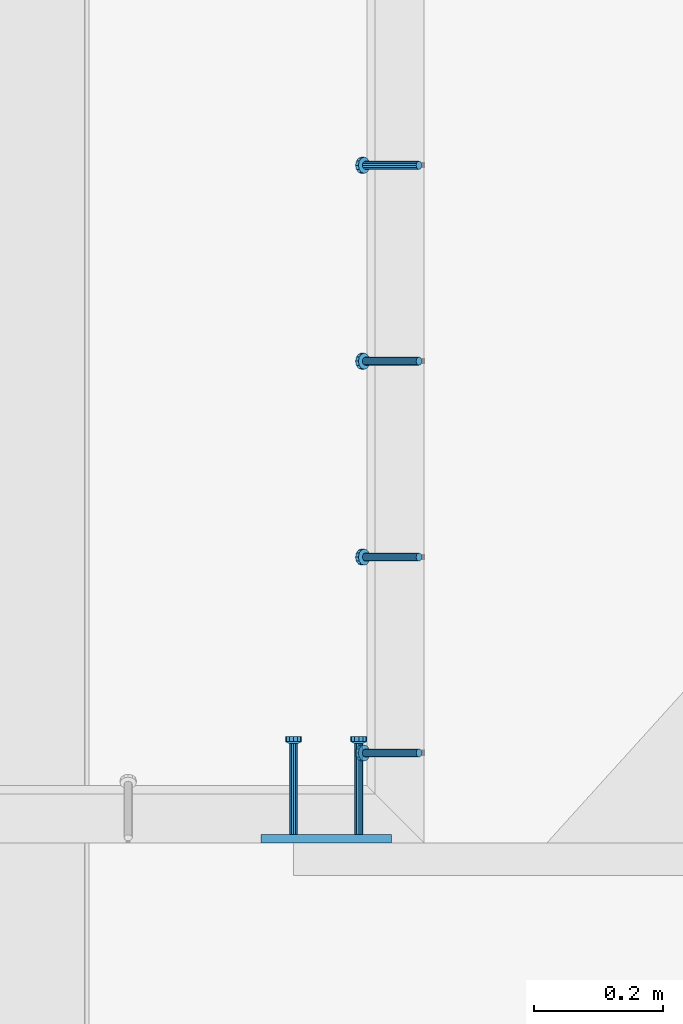
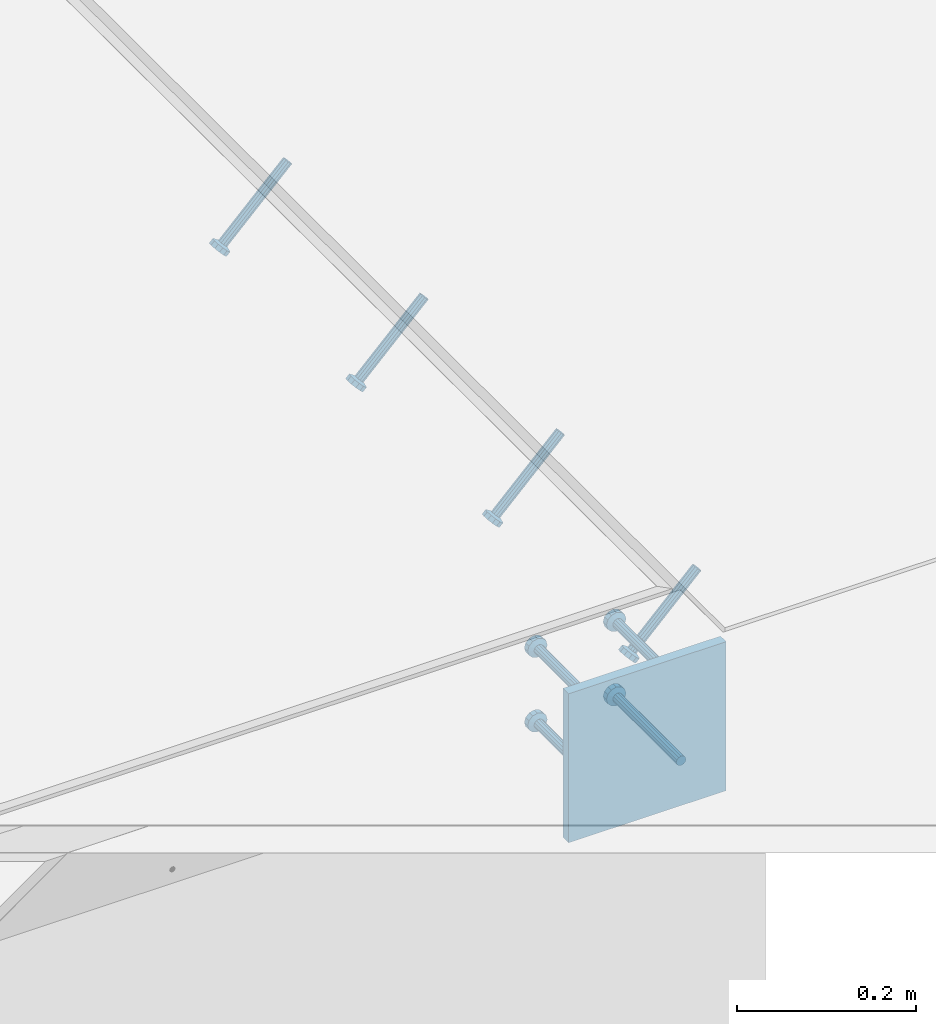
# One storey, part 2160 of 3843: 5 beams, 4 members, 2 elements without a shape of their own.
"""IFC2X3 building model written with IfcOpenShell, lengths in millimetres."""

from ifc_helpers import new_model, si_unit, frame, origin_with_axes, place, context, subcontext, project, spatial, faceted_brep, material, type_object, element, aggregate, save


model = new_model("IFC2X3")

# Units and contexts
model_context = context("Model", 3, precision=1e-05, world=origin_with_axes())
body_context = subcontext(model_context, "Body", "Model", "MODEL_VIEW")
ifc_project = project(units=[si_unit("LENGTHUNIT", "METRE", prefix="MILLI"), si_unit("AREAUNIT", "SQUARE_METRE"), si_unit("VOLUMEUNIT", "CUBIC_METRE"), si_unit("MASSUNIT", "GRAM", prefix="KILO"), si_unit("TIMEUNIT", "SECOND"), si_unit("PLANEANGLEUNIT", "RADIAN"), si_unit("SOLIDANGLEUNIT", "STERADIAN"), si_unit("THERMODYNAMICTEMPERATUREUNIT", "DEGREE_CELSIUS"), si_unit("LUMINOUSINTENSITYUNIT", "LUMEN")], contexts=[model_context])

# Site, building, storey
site_placement = place(None, origin_with_axes())
site = spatial("IfcSite", under=ifc_project, at=site_placement, CompositionType="ELEMENT")
building_placement = place(site_placement, origin_with_axes())
building = spatial("IfcBuilding", under=site, at=building_placement, Name="Undefined", CompositionType="ELEMENT")
storey_placement = place(building_placement, origin_with_axes())
storey = spatial("IfcBuildingStorey", under=building, at=storey_placement, Name="Undefined", CompositionType="ELEMENT", Elevation=0.0)

# Assembly, members
assembly_1_placement = place(storey_placement, origin_with_axes())
assembly_1 = element("IfcElementAssembly", 1, at=assembly_1_placement, inside=storey, Name="EMBED_ANGLE", AssemblyPlace="NOTDEFINED", PredefinedType="RIGID_FRAME")
ifc_material_1 = material(Name="STEEL/A108")
member_type = type_object("IfcMemberType", PredefinedType="NOTDEFINED")
member_1_placement = place(assembly_1_placement, frame((65137.5380556641, 28968.8271953125, 30446.6625), z_axis=(0.0, 1.0, 0.0), x_axis=(-0.707106781186548, 0.0, -0.707106781186548)))
member_1 = element("IfcMember", 2, at=member_1_placement, type_object=member_type, material=ifc_material_1, Name="HEADED STUD ANCHOR", context=body_context, shape_type="Brep", body=[
    faceted_brep([(7.27595761418343e-12, -3.18000006675175, 5.5), (0.0, -5.49999999998363, 3.1800000667572), (118.110000000976, -5.49999999999091, 3.1800000667572), (118.110000000983, -3.18000006675175, 5.5), (0.0, -6.3499999046162, 0.0), (118.110000000968, -6.34999990461256, 0.0), (0.0, -5.49999999998363, -3.1800000667572), (118.110000000976, -5.49999999999091, -3.1800000667572), (7.27595761418343e-12, -3.18000006675175, -5.5), (118.110000000983, -3.18000006675175, -5.5), (7.27595761418343e-12, -1.81898940354586e-12, -6.34999990463257), (118.110000000968, -1.81898940354586e-12, -6.34999990463257), (0.0, 3.18000006675175, -5.5), (118.110000000968, 3.18000006674811, -5.5), (7.27595761418343e-12, 5.49999999998363, -3.1800000667572), (118.110000000983, 5.49999999998363, -3.1800000667572), (7.27595761418343e-12, 6.3499999046162, 0.0), (118.110000000976, 6.34999990461256, 0.0), (7.27595761418343e-12, 5.49999999998363, 3.1800000667572), (118.110000000983, 5.49999999998363, 3.1800000667572), (0.0, 3.18000006675175, 5.5), (118.110000000968, 3.18000006674811, 5.5), (7.27595761418343e-12, -1.81898940354586e-12, 6.34999990463257), (118.110000000968, -1.81898940354586e-12, 6.34999990463257), (120.650000000991, -10.9899997710909, 6.34999990463257), (120.650000000998, -6.34000015257152, 10.9899997711182), (120.650000000991, -12.6999998092379, 0.0), (120.650000000991, -10.9899997710909, -6.34999990463257), (120.650000000998, -6.34000015257152, -10.9899997711182), (120.650000000991, -1.81898940354586e-12, -12.6899995803833), (120.650000000991, 6.34000015257152, -10.9899997711182), (120.650000000998, 10.9899997710909, -6.34999990463257), (120.650000000991, 12.6999998092342, 0.0), (120.650000000998, 10.9899997710909, 6.34999990463257), (120.650000000991, 6.34000015257152, 10.9899997711182), (120.650000000991, -1.81898940354586e-12, 12.6899995803833), (127.000000001048, -10.9899997710945, 6.34999990463257), (127.000000001048, -6.34000015257152, 10.9899997711182), (127.000000001048, -12.6999998092342, 0.0), (127.000000001048, -10.9899997710945, -6.34999990463257), (127.000000001048, -6.34000015257152, -10.9899997711182), (127.000000001048, 1.81898940354586e-12, -12.6899995803833), (127.000000001048, 6.34000015256788, -10.9899997711182), (127.000000001048, 10.9899997710909, -6.34999990463257), (127.000000001048, 12.6999998092379, 0.0), (127.000000001048, 10.9899997710909, 6.34999990463257), (127.000000001048, 6.34000015256788, 10.9899997711182), (127.000000001048, 1.81898940354586e-12, 12.6899995803833)], [[[0, 1, 2, 3]], [[1, 4, 5, 2]], [[4, 6, 7, 5]], [[6, 8, 9, 7]], [[8, 10, 11, 9]], [[10, 12, 13, 11]], [[12, 14, 15, 13]], [[14, 16, 17, 15]], [[16, 18, 19, 17]], [[18, 20, 21, 19]], [[20, 22, 23, 21]], [[22, 0, 3, 23]], [[22, 20, 18, 16, 14, 12, 10, 8, 6, 4, 1, 0]], [[3, 2, 24, 25]], [[2, 5, 26, 24]], [[5, 7, 27, 26]], [[7, 9, 28, 27]], [[9, 11, 29, 28]], [[11, 13, 30, 29]], [[13, 15, 31, 30]], [[15, 17, 32, 31]], [[17, 19, 33, 32]], [[19, 21, 34, 33]], [[21, 23, 35, 34]], [[23, 3, 25, 35]], [[25, 24, 36, 37]], [[24, 26, 38, 36]], [[26, 27, 39, 38]], [[27, 28, 40, 39]], [[28, 29, 41, 40]], [[29, 30, 42, 41]], [[30, 31, 43, 42]], [[31, 32, 44, 43]], [[32, 33, 45, 44]], [[33, 34, 46, 45]], [[34, 35, 47, 46]], [[35, 25, 37, 47]], [[38, 39, 40, 41, 42, 43, 44, 45, 46, 47, 37, 36]]]),
])
member_2_placement = place(assembly_1_placement, frame((65137.5380556641, 29273.6271953125, 30446.6625), z_axis=(0.0, 1.0, 0.0), x_axis=(-0.707106781186548, 0.0, -0.707106781186548)))
member_2 = element("IfcMember", 3, at=member_2_placement, type_object=member_type, material=ifc_material_1, Name="HEADED STUD ANCHOR", context=body_context, shape_type="Brep", body=[
    faceted_brep([(7.27595761418343e-12, -3.18000006675175, 5.5), (0.0, -5.49999999998363, 3.1800000667572), (118.110000000976, -5.49999999999091, 3.1800000667572), (118.110000000983, -3.18000006675175, 5.5), (0.0, -6.3499999046162, 0.0), (118.110000000968, -6.34999990461256, 0.0), (0.0, -5.49999999998363, -3.1800000667572), (118.110000000976, -5.49999999999091, -3.1800000667572), (7.27595761418343e-12, -3.18000006675175, -5.5), (118.110000000983, -3.18000006675175, -5.5), (7.27595761418343e-12, -1.81898940354586e-12, -6.34999990463257), (118.110000000968, -1.81898940354586e-12, -6.34999990463257), (0.0, 3.18000006675175, -5.5), (118.110000000968, 3.18000006674811, -5.5), (7.27595761418343e-12, 5.49999999998363, -3.1800000667572), (118.110000000983, 5.49999999998363, -3.1800000667572), (7.27595761418343e-12, 6.3499999046162, 0.0), (118.110000000976, 6.34999990461256, 0.0), (7.27595761418343e-12, 5.49999999998363, 3.1800000667572), (118.110000000983, 5.49999999998363, 3.1800000667572), (0.0, 3.18000006675175, 5.5), (118.110000000968, 3.18000006674811, 5.5), (7.27595761418343e-12, -1.81898940354586e-12, 6.34999990463257), (118.110000000968, -1.81898940354586e-12, 6.34999990463257), (120.650000000991, -10.9899997710909, 6.34999990463257), (120.650000000998, -6.34000015257152, 10.9899997711182), (120.650000000991, -12.6999998092379, 0.0), (120.650000000991, -10.9899997710909, -6.34999990463257), (120.650000000998, -6.34000015257152, -10.9899997711182), (120.650000000991, -1.81898940354586e-12, -12.6899995803833), (120.650000000991, 6.34000015257152, -10.9899997711182), (120.650000000998, 10.9899997710909, -6.34999990463257), (120.650000000991, 12.6999998092342, 0.0), (120.650000000998, 10.9899997710909, 6.34999990463257), (120.650000000991, 6.34000015257152, 10.9899997711182), (120.650000000991, -1.81898940354586e-12, 12.6899995803833), (127.000000001048, -10.9899997710945, 6.34999990463257), (127.000000001048, -6.34000015257152, 10.9899997711182), (127.000000001048, -12.6999998092342, 0.0), (127.000000001048, -10.9899997710945, -6.34999990463257), (127.000000001048, -6.34000015257152, -10.9899997711182), (127.000000001048, 1.81898940354586e-12, -12.6899995803833), (127.000000001048, 6.34000015256788, -10.9899997711182), (127.000000001048, 10.9899997710909, -6.34999990463257), (127.000000001048, 12.6999998092379, 0.0), (127.000000001048, 10.9899997710909, 6.34999990463257), (127.000000001048, 6.34000015256788, 10.9899997711182), (127.000000001048, 1.81898940354586e-12, 12.6899995803833)], [[[0, 1, 2, 3]], [[1, 4, 5, 2]], [[4, 6, 7, 5]], [[6, 8, 9, 7]], [[8, 10, 11, 9]], [[10, 12, 13, 11]], [[12, 14, 15, 13]], [[14, 16, 17, 15]], [[16, 18, 19, 17]], [[18, 20, 21, 19]], [[20, 22, 23, 21]], [[22, 0, 3, 23]], [[22, 20, 18, 16, 14, 12, 10, 8, 6, 4, 1, 0]], [[3, 2, 24, 25]], [[2, 5, 26, 24]], [[5, 7, 27, 26]], [[7, 9, 28, 27]], [[9, 11, 29, 28]], [[11, 13, 30, 29]], [[13, 15, 31, 30]], [[15, 17, 32, 31]], [[17, 19, 33, 32]], [[19, 21, 34, 33]], [[21, 23, 35, 34]], [[23, 3, 25, 35]], [[25, 24, 36, 37]], [[24, 26, 38, 36]], [[26, 27, 39, 38]], [[27, 28, 40, 39]], [[28, 29, 41, 40]], [[29, 30, 42, 41]], [[30, 31, 43, 42]], [[31, 32, 44, 43]], [[32, 33, 45, 44]], [[33, 34, 46, 45]], [[34, 35, 47, 46]], [[35, 25, 37, 47]], [[38, 39, 40, 41, 42, 43, 44, 45, 46, 47, 37, 36]]]),
])
member_3_placement = place(assembly_1_placement, frame((65137.5380556641, 29578.4271953125, 30446.6625), z_axis=(0.0, 1.0, 0.0), x_axis=(-0.707106781186548, 0.0, -0.707106781186548)))
member_3 = element("IfcMember", 4, at=member_3_placement, type_object=member_type, material=ifc_material_1, Name="HEADED STUD ANCHOR", context=body_context, shape_type="Brep", body=[
    faceted_brep([(7.27595761418343e-12, -3.18000006675175, 5.5), (0.0, -5.49999999998363, 3.1800000667572), (118.110000000976, -5.49999999999091, 3.1800000667572), (118.110000000983, -3.18000006675175, 5.5), (0.0, -6.3499999046162, 0.0), (118.110000000968, -6.34999990461256, 0.0), (0.0, -5.49999999998363, -3.1800000667572), (118.110000000976, -5.49999999999091, -3.1800000667572), (7.27595761418343e-12, -3.18000006675175, -5.5), (118.110000000983, -3.18000006675175, -5.5), (7.27595761418343e-12, -1.81898940354586e-12, -6.34999990463257), (118.110000000968, -1.81898940354586e-12, -6.34999990463257), (0.0, 3.18000006675175, -5.5), (118.110000000968, 3.18000006674811, -5.5), (7.27595761418343e-12, 5.49999999998363, -3.1800000667572), (118.110000000983, 5.49999999998363, -3.1800000667572), (7.27595761418343e-12, 6.3499999046162, 0.0), (118.110000000976, 6.34999990461256, 0.0), (7.27595761418343e-12, 5.49999999998363, 3.1800000667572), (118.110000000983, 5.49999999998363, 3.1800000667572), (0.0, 3.18000006675175, 5.5), (118.110000000968, 3.18000006674811, 5.5), (7.27595761418343e-12, -1.81898940354586e-12, 6.34999990463257), (118.110000000968, -1.81898940354586e-12, 6.34999990463257), (120.650000000991, -10.9899997710909, 6.34999990463257), (120.650000000998, -6.34000015257152, 10.9899997711182), (120.650000000991, -12.6999998092379, 0.0), (120.650000000991, -10.9899997710909, -6.34999990463257), (120.650000000998, -6.34000015257152, -10.9899997711182), (120.650000000991, -1.81898940354586e-12, -12.6899995803833), (120.650000000991, 6.34000015257152, -10.9899997711182), (120.650000000998, 10.9899997710909, -6.34999990463257), (120.650000000991, 12.6999998092342, 0.0), (120.650000000998, 10.9899997710909, 6.34999990463257), (120.650000000991, 6.34000015257152, 10.9899997711182), (120.650000000991, -1.81898940354586e-12, 12.6899995803833), (127.000000001048, -10.9899997710945, 6.34999990463257), (127.000000001048, -6.34000015257152, 10.9899997711182), (127.000000001048, -12.6999998092342, 0.0), (127.000000001048, -10.9899997710945, -6.34999990463257), (127.000000001048, -6.34000015257152, -10.9899997711182), (127.000000001048, 1.81898940354586e-12, -12.6899995803833), (127.000000001048, 6.34000015256788, -10.9899997711182), (127.000000001048, 10.9899997710909, -6.34999990463257), (127.000000001048, 12.6999998092379, 0.0), (127.000000001048, 10.9899997710909, 6.34999990463257), (127.000000001048, 6.34000015256788, 10.9899997711182), (127.000000001048, 1.81898940354586e-12, 12.6899995803833)], [[[0, 1, 2, 3]], [[1, 4, 5, 2]], [[4, 6, 7, 5]], [[6, 8, 9, 7]], [[8, 10, 11, 9]], [[10, 12, 13, 11]], [[12, 14, 15, 13]], [[14, 16, 17, 15]], [[16, 18, 19, 17]], [[18, 20, 21, 19]], [[20, 22, 23, 21]], [[22, 0, 3, 23]], [[22, 20, 18, 16, 14, 12, 10, 8, 6, 4, 1, 0]], [[3, 2, 24, 25]], [[2, 5, 26, 24]], [[5, 7, 27, 26]], [[7, 9, 28, 27]], [[9, 11, 29, 28]], [[11, 13, 30, 29]], [[13, 15, 31, 30]], [[15, 17, 32, 31]], [[17, 19, 33, 32]], [[19, 21, 34, 33]], [[21, 23, 35, 34]], [[23, 3, 25, 35]], [[25, 24, 36, 37]], [[24, 26, 38, 36]], [[26, 27, 39, 38]], [[27, 28, 40, 39]], [[28, 29, 41, 40]], [[29, 30, 42, 41]], [[30, 31, 43, 42]], [[31, 32, 44, 43]], [[32, 33, 45, 44]], [[33, 34, 46, 45]], [[34, 35, 47, 46]], [[35, 25, 37, 47]], [[38, 39, 40, 41, 42, 43, 44, 45, 46, 47, 37, 36]]]),
])
member_4_placement = place(assembly_1_placement, frame((65137.5380556641, 29883.2271953125, 30446.6625), z_axis=(0.0, 1.0, 0.0), x_axis=(-0.707106781186548, 0.0, -0.707106781186548)))
member_4 = element("IfcMember", 5, at=member_4_placement, type_object=member_type, material=ifc_material_1, Name="HEADED STUD ANCHOR", context=body_context, shape_type="Brep", body=[
    faceted_brep([(7.27595761418343e-12, -3.18000006675175, 5.5), (0.0, -5.49999999998363, 3.1800000667572), (118.110000000976, -5.49999999999091, 3.1800000667572), (118.110000000983, -3.18000006675175, 5.5), (0.0, -6.3499999046162, 0.0), (118.110000000968, -6.34999990461256, 0.0), (0.0, -5.49999999998363, -3.1800000667572), (118.110000000976, -5.49999999999091, -3.1800000667572), (7.27595761418343e-12, -3.18000006675175, -5.5), (118.110000000983, -3.18000006675175, -5.5), (7.27595761418343e-12, -1.81898940354586e-12, -6.34999990463257), (118.110000000968, -1.81898940354586e-12, -6.34999990463257), (0.0, 3.18000006675175, -5.5), (118.110000000968, 3.18000006674811, -5.5), (7.27595761418343e-12, 5.49999999998363, -3.1800000667572), (118.110000000983, 5.49999999998363, -3.1800000667572), (7.27595761418343e-12, 6.3499999046162, 0.0), (118.110000000976, 6.34999990461256, 0.0), (7.27595761418343e-12, 5.49999999998363, 3.1800000667572), (118.110000000983, 5.49999999998363, 3.1800000667572), (0.0, 3.18000006675175, 5.5), (118.110000000968, 3.18000006674811, 5.5), (7.27595761418343e-12, -1.81898940354586e-12, 6.34999990463257), (118.110000000968, -1.81898940354586e-12, 6.34999990463257), (120.650000000991, -10.9899997710909, 6.34999990463257), (120.650000000998, -6.34000015257152, 10.9899997711182), (120.650000000991, -12.6999998092379, 0.0), (120.650000000991, -10.9899997710909, -6.34999990463257), (120.650000000998, -6.34000015257152, -10.9899997711182), (120.650000000991, -1.81898940354586e-12, -12.6899995803833), (120.650000000991, 6.34000015257152, -10.9899997711182), (120.650000000998, 10.9899997710909, -6.34999990463257), (120.650000000991, 12.6999998092342, 0.0), (120.650000000998, 10.9899997710909, 6.34999990463257), (120.650000000991, 6.34000015257152, 10.9899997711182), (120.650000000991, -1.81898940354586e-12, 12.6899995803833), (127.000000001048, -10.9899997710945, 6.34999990463257), (127.000000001048, -6.34000015257152, 10.9899997711182), (127.000000001048, -12.6999998092342, 0.0), (127.000000001048, -10.9899997710945, -6.34999990463257), (127.000000001048, -6.34000015257152, -10.9899997711182), (127.000000001048, 1.81898940354586e-12, -12.6899995803833), (127.000000001048, 6.34000015256788, -10.9899997711182), (127.000000001048, 10.9899997710909, -6.34999990463257), (127.000000001048, 12.6999998092379, 0.0), (127.000000001048, 10.9899997710909, 6.34999990463257), (127.000000001048, 6.34000015256788, 10.9899997711182), (127.000000001048, 1.81898940354586e-12, 12.6899995803833)], [[[0, 1, 2, 3]], [[1, 4, 5, 2]], [[4, 6, 7, 5]], [[6, 8, 9, 7]], [[8, 10, 11, 9]], [[10, 12, 13, 11]], [[12, 14, 15, 13]], [[14, 16, 17, 15]], [[16, 18, 19, 17]], [[18, 20, 21, 19]], [[20, 22, 23, 21]], [[22, 0, 3, 23]], [[22, 20, 18, 16, 14, 12, 10, 8, 6, 4, 1, 0]], [[3, 2, 24, 25]], [[2, 5, 26, 24]], [[5, 7, 27, 26]], [[7, 9, 28, 27]], [[9, 11, 29, 28]], [[11, 13, 30, 29]], [[13, 15, 31, 30]], [[15, 17, 32, 31]], [[17, 19, 33, 32]], [[19, 21, 34, 33]], [[21, 23, 35, 34]], [[23, 3, 25, 35]], [[25, 24, 36, 37]], [[24, 26, 38, 36]], [[26, 27, 39, 38]], [[27, 28, 40, 39]], [[28, 29, 41, 40]], [[29, 30, 42, 41]], [[30, 31, 43, 42]], [[31, 32, 44, 43]], [[32, 33, 45, 44]], [[33, 34, 46, 45]], [[34, 35, 47, 46]], [[35, 25, 37, 47]], [[38, 39, 40, 41, 42, 43, 44, 45, 46, 47, 37, 36]]]),
])
aggregate(assembly_1, [member_1, member_2, member_3, member_4])

# Assembly, beams
assembly_2_placement = place(storey_placement, origin_with_axes())
assembly_2 = element("IfcElementAssembly", 6, at=assembly_2_placement, inside=storey, Name="EMBED PLATE", AssemblyPlace="NOTDEFINED", PredefinedType="RIGID_FRAME")
ifc_material_2 = material(Name="STEEL/A36")
beam_type_1 = type_object("IfcBeamType", PredefinedType="NOTDEFINED")
beam_1_placement = place(assembly_2_placement, frame((64993.0120976562, 28835.35, 30445.075), z_axis=(1.0, 0.0, 0.0), x_axis=(0.0, 0.0, -1.0)))
beam_1 = element("IfcBeam", 7, at=beam_1_placement, type_object=beam_type_1, material=ifc_material_2, Name="EMBED PLATE", context=body_context, shape_type="Brep", body=[
    faceted_brep([(1.74622982740402e-10, 6.35000000000582, -101.600000000195), (-1.67347025126219e-10, 6.35000000000582, 101.600000000151), (203.200000000001, 6.35000000000582, 101.599999999999), (203.200000000001, 6.35000000000582, -101.599999999999), (-1.67347025126219e-10, -6.35000000000582, 101.600000000151), (203.200000000001, -6.35000000000582, 101.599999999999), (1.74622982740402e-10, -6.35000000000582, -101.600000000195), (203.200000000001, -6.35000000000582, -101.599999999999)], [[[0, 1, 2, 3]], [[1, 4, 5, 2]], [[4, 6, 7, 5]], [[6, 0, 3, 7]], [[5, 7, 3, 2]], [[6, 4, 1, 0]]]),
])
beam_type_2 = type_object("IfcBeamType", PredefinedType="NOTDEFINED")
beam_2_placement = place(assembly_2_placement, frame((64942.2120976562, 28841.7, 30394.275), z_axis=(-1.0, 0.0, 0.0), x_axis=(0.0, 1.0, 0.0)))
beam_2 = element("IfcBeam", 8, at=beam_2_placement, type_object=beam_type_2, material=ifc_material_1, Name="HEADED STUD ANCHOR", context=body_context, shape_type="Brep", body=[
    faceted_brep([(7.27595761418343e-12, -3.18000006675175, 5.5), (0.0, -5.49999999998363, 3.1800000667572), (141.731999999989, -5.5, 3.1800000667572), (141.731999999989, -3.1800000667572, 5.5), (0.0, -6.3499999046162, 0.0), (141.731999999989, -6.34999990463257, 0.0), (0.0, -5.49999999998363, -3.1800000667572), (141.731999999989, -5.5, -3.1800000667572), (7.27595761418343e-12, -3.18000006675175, -5.5), (141.731999999989, -3.1800000667572, -5.5), (7.27595761418343e-12, -1.81898940354586e-12, -6.34999990463257), (141.731999999989, 0.0, -6.34999990463257), (0.0, 3.18000006675175, -5.5), (141.731999999989, 3.1800000667572, -5.5), (7.27595761418343e-12, 5.49999999998363, -3.1800000667572), (141.731999999989, 5.5, -3.1800000667572), (7.27595761418343e-12, 6.3499999046162, 0.0), (141.731999999989, 6.34999990463257, 0.0), (7.27595761418343e-12, 5.49999999998363, 3.1800000667572), (141.731999999989, 5.5, 3.1800000667572), (0.0, 3.18000006675175, 5.5), (141.731999999989, 3.1800000667572, 5.5), (7.27595761418343e-12, -1.81898940354586e-12, 6.34999990463257), (141.731999999989, 0.0, 6.34999990463257), (144.779999999999, -10.9899997711182, 6.34999990463257), (144.779999999999, -6.34000015258789, 10.9899997711182), (144.779999999999, -12.6999998092651, 0.0), (144.779999999999, -10.9899997711182, -6.34999990463257), (144.779999999999, -6.34000015258789, -10.9899997711182), (144.779999999999, 0.0, -12.6899995803833), (144.779999999999, 6.34000015258789, -10.9899997711182), (144.779999999999, 10.9899997711182, -6.34999990463257), (144.779999999999, 12.6999998092651, 0.0), (144.779999999999, 10.9899997711182, 6.34999990463257), (144.779999999999, 6.34000015258789, 10.9899997711182), (144.779999999999, 0.0, 12.6899995803833), (152.399999999994, -10.9899997711182, 6.34999990463257), (152.399999999994, -6.34000015258789, 10.9899997711182), (152.399999999994, -12.6999998092651, 0.0), (152.399999999994, -10.9899997711182, -6.34999990463257), (152.399999999994, -6.34000015258789, -10.9899997711182), (152.399999999994, 0.0, -12.6899995803833), (152.399999999994, 6.34000015258789, -10.9899997711182), (152.399999999994, 10.9899997711182, -6.34999990463257), (152.399999999994, 12.6999998092651, 0.0), (152.399999999994, 10.9899997711182, 6.34999990463257), (152.399999999994, 6.34000015258789, 10.9899997711182), (152.399999999994, 0.0, 12.6899995803833)], [[[0, 1, 2, 3]], [[1, 4, 5, 2]], [[4, 6, 7, 5]], [[6, 8, 9, 7]], [[8, 10, 11, 9]], [[10, 12, 13, 11]], [[12, 14, 15, 13]], [[14, 16, 17, 15]], [[16, 18, 19, 17]], [[18, 20, 21, 19]], [[20, 22, 23, 21]], [[22, 0, 3, 23]], [[22, 20, 18, 16, 14, 12, 10, 8, 6, 4, 1, 0]], [[3, 2, 24, 25]], [[2, 5, 26, 24]], [[5, 7, 27, 26]], [[7, 9, 28, 27]], [[9, 11, 29, 28]], [[11, 13, 30, 29]], [[13, 15, 31, 30]], [[15, 17, 32, 31]], [[17, 19, 33, 32]], [[19, 21, 34, 33]], [[21, 23, 35, 34]], [[23, 3, 25, 35]], [[25, 24, 36, 37]], [[24, 26, 38, 36]], [[26, 27, 39, 38]], [[27, 28, 40, 39]], [[28, 29, 41, 40]], [[29, 30, 42, 41]], [[30, 31, 43, 42]], [[31, 32, 44, 43]], [[32, 33, 45, 44]], [[33, 34, 46, 45]], [[34, 35, 47, 46]], [[35, 25, 37, 47]], [[38, 39, 40, 41, 42, 43, 44, 45, 46, 47, 37, 36]]]),
])
beam_3_placement = place(assembly_2_placement, frame((64942.2120976562, 28841.7, 30292.675), z_axis=(-1.0, 0.0, 0.0), x_axis=(0.0, 1.0, 0.0)))
beam_3 = element("IfcBeam", 9, at=beam_3_placement, type_object=beam_type_2, material=ifc_material_1, Name="HEADED STUD ANCHOR", context=body_context, shape_type="Brep", body=[
    faceted_brep([(7.27595761418343e-12, -3.18000006675175, 5.5), (0.0, -5.49999999998363, 3.1800000667572), (141.731999999989, -5.5, 3.1800000667572), (141.731999999989, -3.1800000667572, 5.5), (0.0, -6.3499999046162, 0.0), (141.731999999989, -6.34999990463257, 0.0), (0.0, -5.49999999998363, -3.1800000667572), (141.731999999989, -5.5, -3.1800000667572), (7.27595761418343e-12, -3.18000006675175, -5.5), (141.731999999989, -3.1800000667572, -5.5), (7.27595761418343e-12, -1.81898940354586e-12, -6.34999990463257), (141.731999999989, 0.0, -6.34999990463257), (0.0, 3.18000006675175, -5.5), (141.731999999989, 3.1800000667572, -5.5), (7.27595761418343e-12, 5.49999999998363, -3.1800000667572), (141.731999999989, 5.5, -3.1800000667572), (7.27595761418343e-12, 6.3499999046162, 0.0), (141.731999999989, 6.34999990463257, 0.0), (7.27595761418343e-12, 5.49999999998363, 3.1800000667572), (141.731999999989, 5.5, 3.1800000667572), (0.0, 3.18000006675175, 5.5), (141.731999999989, 3.1800000667572, 5.5), (7.27595761418343e-12, -1.81898940354586e-12, 6.34999990463257), (141.731999999989, 0.0, 6.34999990463257), (144.779999999999, -10.9899997711182, 6.34999990463257), (144.779999999999, -6.34000015258789, 10.9899997711182), (144.779999999999, -12.6999998092651, 0.0), (144.779999999999, -10.9899997711182, -6.34999990463257), (144.779999999999, -6.34000015258789, -10.9899997711182), (144.779999999999, 0.0, -12.6899995803833), (144.779999999999, 6.34000015258789, -10.9899997711182), (144.779999999999, 10.9899997711182, -6.34999990463257), (144.779999999999, 12.6999998092651, 0.0), (144.779999999999, 10.9899997711182, 6.34999990463257), (144.779999999999, 6.34000015258789, 10.9899997711182), (144.779999999999, 0.0, 12.6899995803833), (152.399999999994, -10.9899997711182, 6.34999990463257), (152.399999999994, -6.34000015258789, 10.9899997711182), (152.399999999994, -12.6999998092651, 0.0), (152.399999999994, -10.9899997711182, -6.34999990463257), (152.399999999994, -6.34000015258789, -10.9899997711182), (152.399999999994, 0.0, -12.6899995803833), (152.399999999994, 6.34000015258789, -10.9899997711182), (152.399999999994, 10.9899997711182, -6.34999990463257), (152.399999999994, 12.6999998092651, 0.0), (152.399999999994, 10.9899997711182, 6.34999990463257), (152.399999999994, 6.34000015258789, 10.9899997711182), (152.399999999994, 0.0, 12.6899995803833)], [[[0, 1, 2, 3]], [[1, 4, 5, 2]], [[4, 6, 7, 5]], [[6, 8, 9, 7]], [[8, 10, 11, 9]], [[10, 12, 13, 11]], [[12, 14, 15, 13]], [[14, 16, 17, 15]], [[16, 18, 19, 17]], [[18, 20, 21, 19]], [[20, 22, 23, 21]], [[22, 0, 3, 23]], [[22, 20, 18, 16, 14, 12, 10, 8, 6, 4, 1, 0]], [[3, 2, 24, 25]], [[2, 5, 26, 24]], [[5, 7, 27, 26]], [[7, 9, 28, 27]], [[9, 11, 29, 28]], [[11, 13, 30, 29]], [[13, 15, 31, 30]], [[15, 17, 32, 31]], [[17, 19, 33, 32]], [[19, 21, 34, 33]], [[21, 23, 35, 34]], [[23, 3, 25, 35]], [[25, 24, 36, 37]], [[24, 26, 38, 36]], [[26, 27, 39, 38]], [[27, 28, 40, 39]], [[28, 29, 41, 40]], [[29, 30, 42, 41]], [[30, 31, 43, 42]], [[31, 32, 44, 43]], [[32, 33, 45, 44]], [[33, 34, 46, 45]], [[34, 35, 47, 46]], [[35, 25, 37, 47]], [[38, 39, 40, 41, 42, 43, 44, 45, 46, 47, 37, 36]]]),
])
beam_4_placement = place(assembly_2_placement, frame((65043.8120976562, 28841.7, 30394.275), z_axis=(-1.0, 0.0, 0.0), x_axis=(0.0, 1.0, 0.0)))
beam_4 = element("IfcBeam", 10, at=beam_4_placement, type_object=beam_type_2, material=ifc_material_1, Name="HEADED STUD ANCHOR", context=body_context, shape_type="Brep", body=[
    faceted_brep([(7.27595761418343e-12, -3.18000006675175, 5.5), (0.0, -5.49999999998363, 3.1800000667572), (141.731999999989, -5.5, 3.1800000667572), (141.731999999989, -3.1800000667572, 5.5), (0.0, -6.3499999046162, 0.0), (141.731999999989, -6.34999990463257, 0.0), (0.0, -5.49999999998363, -3.1800000667572), (141.731999999989, -5.5, -3.1800000667572), (7.27595761418343e-12, -3.18000006675175, -5.5), (141.731999999989, -3.1800000667572, -5.5), (7.27595761418343e-12, -1.81898940354586e-12, -6.34999990463257), (141.731999999989, 0.0, -6.34999990463257), (0.0, 3.18000006675175, -5.5), (141.731999999989, 3.1800000667572, -5.5), (7.27595761418343e-12, 5.49999999998363, -3.1800000667572), (141.731999999989, 5.5, -3.1800000667572), (7.27595761418343e-12, 6.3499999046162, 0.0), (141.731999999989, 6.34999990463257, 0.0), (7.27595761418343e-12, 5.49999999998363, 3.1800000667572), (141.731999999989, 5.5, 3.1800000667572), (0.0, 3.18000006675175, 5.5), (141.731999999989, 3.1800000667572, 5.5), (7.27595761418343e-12, -1.81898940354586e-12, 6.34999990463257), (141.731999999989, 0.0, 6.34999990463257), (144.779999999999, -10.9899997711182, 6.34999990463257), (144.779999999999, -6.34000015258789, 10.9899997711182), (144.779999999999, -12.6999998092651, 0.0), (144.779999999999, -10.9899997711182, -6.34999990463257), (144.779999999999, -6.34000015258789, -10.9899997711182), (144.779999999999, 0.0, -12.6899995803833), (144.779999999999, 6.34000015258789, -10.9899997711182), (144.779999999999, 10.9899997711182, -6.34999990463257), (144.779999999999, 12.6999998092651, 0.0), (144.779999999999, 10.9899997711182, 6.34999990463257), (144.779999999999, 6.34000015258789, 10.9899997711182), (144.779999999999, 0.0, 12.6899995803833), (152.399999999994, -10.9899997711182, 6.34999990463257), (152.399999999994, -6.34000015258789, 10.9899997711182), (152.399999999994, -12.6999998092651, 0.0), (152.399999999994, -10.9899997711182, -6.34999990463257), (152.399999999994, -6.34000015258789, -10.9899997711182), (152.399999999994, 0.0, -12.6899995803833), (152.399999999994, 6.34000015258789, -10.9899997711182), (152.399999999994, 10.9899997711182, -6.34999990463257), (152.399999999994, 12.6999998092651, 0.0), (152.399999999994, 10.9899997711182, 6.34999990463257), (152.399999999994, 6.34000015258789, 10.9899997711182), (152.399999999994, 0.0, 12.6899995803833)], [[[0, 1, 2, 3]], [[1, 4, 5, 2]], [[4, 6, 7, 5]], [[6, 8, 9, 7]], [[8, 10, 11, 9]], [[10, 12, 13, 11]], [[12, 14, 15, 13]], [[14, 16, 17, 15]], [[16, 18, 19, 17]], [[18, 20, 21, 19]], [[20, 22, 23, 21]], [[22, 0, 3, 23]], [[22, 20, 18, 16, 14, 12, 10, 8, 6, 4, 1, 0]], [[3, 2, 24, 25]], [[2, 5, 26, 24]], [[5, 7, 27, 26]], [[7, 9, 28, 27]], [[9, 11, 29, 28]], [[11, 13, 30, 29]], [[13, 15, 31, 30]], [[15, 17, 32, 31]], [[17, 19, 33, 32]], [[19, 21, 34, 33]], [[21, 23, 35, 34]], [[23, 3, 25, 35]], [[25, 24, 36, 37]], [[24, 26, 38, 36]], [[26, 27, 39, 38]], [[27, 28, 40, 39]], [[28, 29, 41, 40]], [[29, 30, 42, 41]], [[30, 31, 43, 42]], [[31, 32, 44, 43]], [[32, 33, 45, 44]], [[33, 34, 46, 45]], [[34, 35, 47, 46]], [[35, 25, 37, 47]], [[38, 39, 40, 41, 42, 43, 44, 45, 46, 47, 37, 36]]]),
])
beam_5_placement = place(assembly_2_placement, frame((65043.8120976562, 28841.7, 30292.675), z_axis=(-1.0, 0.0, 0.0), x_axis=(0.0, 1.0, 0.0)))
beam_5 = element("IfcBeam", 11, at=beam_5_placement, type_object=beam_type_2, material=ifc_material_1, Name="HEADED STUD ANCHOR", context=body_context, shape_type="Brep", body=[
    faceted_brep([(7.27595761418343e-12, -3.18000006675175, 5.5), (0.0, -5.49999999998363, 3.1800000667572), (141.731999999989, -5.5, 3.1800000667572), (141.731999999989, -3.1800000667572, 5.5), (0.0, -6.3499999046162, 0.0), (141.731999999989, -6.34999990463257, 0.0), (0.0, -5.49999999998363, -3.1800000667572), (141.731999999989, -5.5, -3.1800000667572), (7.27595761418343e-12, -3.18000006675175, -5.5), (141.731999999989, -3.1800000667572, -5.5), (7.27595761418343e-12, -1.81898940354586e-12, -6.34999990463257), (141.731999999989, 0.0, -6.34999990463257), (0.0, 3.18000006675175, -5.5), (141.731999999989, 3.1800000667572, -5.5), (7.27595761418343e-12, 5.49999999998363, -3.1800000667572), (141.731999999989, 5.5, -3.1800000667572), (7.27595761418343e-12, 6.3499999046162, 0.0), (141.731999999989, 6.34999990463257, 0.0), (7.27595761418343e-12, 5.49999999998363, 3.1800000667572), (141.731999999989, 5.5, 3.1800000667572), (0.0, 3.18000006675175, 5.5), (141.731999999989, 3.1800000667572, 5.5), (7.27595761418343e-12, -1.81898940354586e-12, 6.34999990463257), (141.731999999989, 0.0, 6.34999990463257), (144.779999999999, -10.9899997711182, 6.34999990463257), (144.779999999999, -6.34000015258789, 10.9899997711182), (144.779999999999, -12.6999998092651, 0.0), (144.779999999999, -10.9899997711182, -6.34999990463257), (144.779999999999, -6.34000015258789, -10.9899997711182), (144.779999999999, 0.0, -12.6899995803833), (144.779999999999, 6.34000015258789, -10.9899997711182), (144.779999999999, 10.9899997711182, -6.34999990463257), (144.779999999999, 12.6999998092651, 0.0), (144.779999999999, 10.9899997711182, 6.34999990463257), (144.779999999999, 6.34000015258789, 10.9899997711182), (144.779999999999, 0.0, 12.6899995803833), (152.399999999994, -10.9899997711182, 6.34999990463257), (152.399999999994, -6.34000015258789, 10.9899997711182), (152.399999999994, -12.6999998092651, 0.0), (152.399999999994, -10.9899997711182, -6.34999990463257), (152.399999999994, -6.34000015258789, -10.9899997711182), (152.399999999994, 0.0, -12.6899995803833), (152.399999999994, 6.34000015258789, -10.9899997711182), (152.399999999994, 10.9899997711182, -6.34999990463257), (152.399999999994, 12.6999998092651, 0.0), (152.399999999994, 10.9899997711182, 6.34999990463257), (152.399999999994, 6.34000015258789, 10.9899997711182), (152.399999999994, 0.0, 12.6899995803833)], [[[0, 1, 2, 3]], [[1, 4, 5, 2]], [[4, 6, 7, 5]], [[6, 8, 9, 7]], [[8, 10, 11, 9]], [[10, 12, 13, 11]], [[12, 14, 15, 13]], [[14, 16, 17, 15]], [[16, 18, 19, 17]], [[18, 20, 21, 19]], [[20, 22, 23, 21]], [[22, 0, 3, 23]], [[22, 20, 18, 16, 14, 12, 10, 8, 6, 4, 1, 0]], [[3, 2, 24, 25]], [[2, 5, 26, 24]], [[5, 7, 27, 26]], [[7, 9, 28, 27]], [[9, 11, 29, 28]], [[11, 13, 30, 29]], [[13, 15, 31, 30]], [[15, 17, 32, 31]], [[17, 19, 33, 32]], [[19, 21, 34, 33]], [[21, 23, 35, 34]], [[23, 3, 25, 35]], [[25, 24, 36, 37]], [[24, 26, 38, 36]], [[26, 27, 39, 38]], [[27, 28, 40, 39]], [[28, 29, 41, 40]], [[29, 30, 42, 41]], [[30, 31, 43, 42]], [[31, 32, 44, 43]], [[32, 33, 45, 44]], [[33, 34, 46, 45]], [[34, 35, 47, 46]], [[35, 25, 37, 47]], [[38, 39, 40, 41, 42, 43, 44, 45, 46, 47, 37, 36]]]),
])
aggregate(assembly_2, [beam_2, beam_3, beam_4, beam_5, beam_1])

save(model, "model.ifc")
